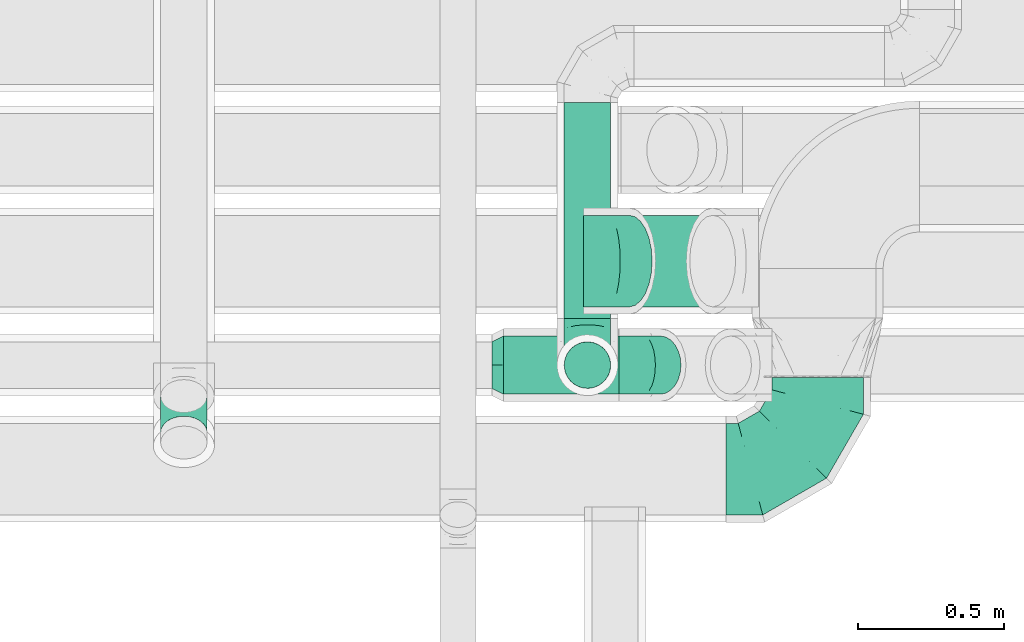
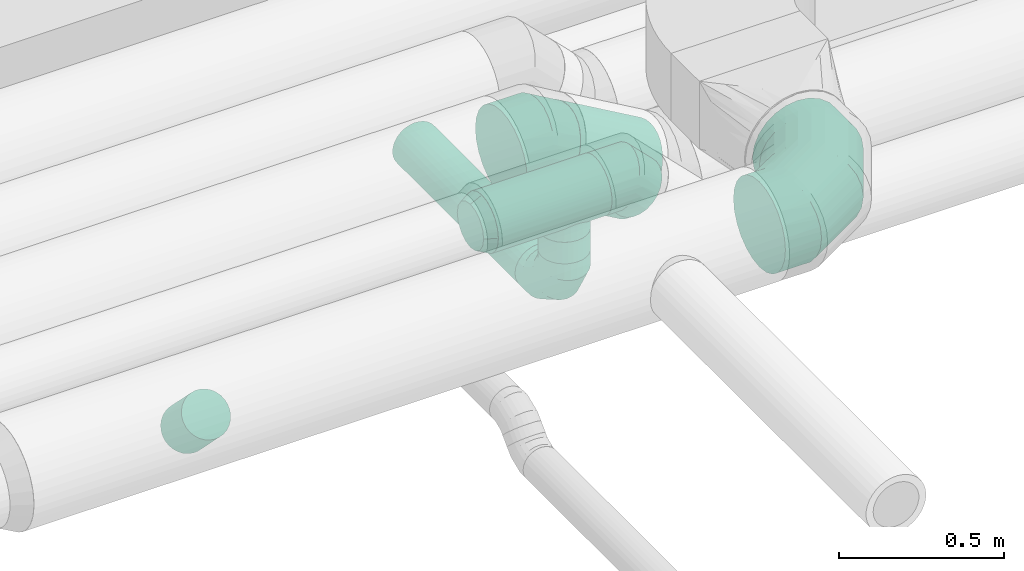
# One storey, part 57 of 92: 6 flow fittings, 5 flow segments.
"""IFC2X3 building model written with IfcOpenShell, lengths in millimetres."""

from ifc_helpers import new_model, entity, si_unit, converted_unit, derived_unit, direction, frame, origin, origin_2d_with_axis, place, context, subcontext, project, spatial, circle, extrude, faceted_brep, source, transform, mapped, material, type_object, type_shapes, element, save


model = new_model("IFC2X3")

# Units and contexts
model_context = context("Model", 3, precision=0.01, world=origin(), true_north=direction((6.12303176911189e-17, 1.0)))
body_context = subcontext(model_context, "Body", "Model", "MODEL_VIEW")
ifc_project = project(units=[si_unit("LENGTHUNIT", "METRE", prefix="MILLI"), si_unit("AREAUNIT", "SQUARE_METRE"), si_unit("VOLUMEUNIT", "CUBIC_METRE"), converted_unit("PLANEANGLEUNIT", "DEGREE", entity("IfcRatioMeasure", 0.0174532925199433), si_unit("PLANEANGLEUNIT", "RADIAN"), dimensions=[0, 0, 0, 0, 0, 0, 0]), si_unit("MASSUNIT", "GRAM", prefix="KILO"), derived_unit("MASSDENSITYUNIT", [(si_unit("MASSUNIT", "GRAM", prefix="KILO"), 1), (si_unit("LENGTHUNIT", "METRE"), -3)]), derived_unit("MOMENTOFINERTIAUNIT", [(si_unit("LENGTHUNIT", "METRE"), 4)]), si_unit("TIMEUNIT", "SECOND"), si_unit("FREQUENCYUNIT", "HERTZ"), si_unit("THERMODYNAMICTEMPERATUREUNIT", "DEGREE_CELSIUS"), derived_unit("THERMALTRANSMITTANCEUNIT", [(si_unit("MASSUNIT", "GRAM", prefix="KILO"), 1), (si_unit("THERMODYNAMICTEMPERATUREUNIT", "KELVIN"), -1), (si_unit("TIMEUNIT", "SECOND"), -3)]), derived_unit("VOLUMETRICFLOWRATEUNIT", [(si_unit("LENGTHUNIT", "METRE"), 3), (si_unit("TIMEUNIT", "SECOND"), -1)]), derived_unit("MASSFLOWRATEUNIT", [(si_unit("MASSUNIT", "GRAM", prefix="KILO"), 1), (si_unit("TIMEUNIT", "SECOND"), -1)]), derived_unit("ROTATIONALFREQUENCYUNIT", [(si_unit("TIMEUNIT", "SECOND"), -1)]), si_unit("ELECTRICCURRENTUNIT", "AMPERE"), si_unit("ELECTRICVOLTAGEUNIT", "VOLT"), si_unit("POWERUNIT", "WATT"), si_unit("FORCEUNIT", "NEWTON", prefix="KILO"), si_unit("ILLUMINANCEUNIT", "LUX"), si_unit("LUMINOUSFLUXUNIT", "LUMEN"), si_unit("LUMINOUSINTENSITYUNIT", "CANDELA"), derived_unit("USERDEFINED", [(si_unit("MASSUNIT", "GRAM", prefix="KILO"), -1), (si_unit("LENGTHUNIT", "METRE"), -2), (si_unit("TIMEUNIT", "SECOND"), 3), (si_unit("LUMINOUSFLUXUNIT", "LUMEN"), 1)]), derived_unit("LINEARVELOCITYUNIT", [(si_unit("LENGTHUNIT", "METRE"), 1), (si_unit("TIMEUNIT", "SECOND"), -1)]), si_unit("PRESSUREUNIT", "PASCAL"), derived_unit("USERDEFINED", [(si_unit("LENGTHUNIT", "METRE"), -2), (si_unit("MASSUNIT", "GRAM", prefix="KILO"), 1), (si_unit("TIMEUNIT", "SECOND"), -2)]), derived_unit("LINEARFORCEUNIT", [(si_unit("MASSUNIT", "GRAM", prefix="KILO"), 1), (si_unit("LENGTHUNIT", "METRE"), 1), (si_unit("TIMEUNIT", "SECOND"), -2), (si_unit("LENGTHUNIT", "METRE"), -1)]), derived_unit("PLANARFORCEUNIT", [(si_unit("MASSUNIT", "GRAM", prefix="KILO"), 1), (si_unit("LENGTHUNIT", "METRE"), 1), (si_unit("TIMEUNIT", "SECOND"), -2), (si_unit("LENGTHUNIT", "METRE"), -2)])], contexts=[model_context])

# Site, building, storey
site_placement = place(None, origin())
site = spatial("IfcSite", under=ifc_project, at=site_placement, CompositionType="ELEMENT")
building_placement = place(site_placement, origin())
building = spatial("IfcBuilding", under=site, at=building_placement, CompositionType="ELEMENT")
storey_placement = place(building_placement, frame((0.0, 0.0, 4200.0)))
storey = spatial("IfcBuildingStorey", under=building, at=storey_placement, CompositionType="ELEMENT", Elevation=4200.0)

# Flow segments
duct_segment_type = type_object("IfcDuctSegmentType", PredefinedType="NOTDEFINED")
flow_segment_1_placement = place(storey_placement, frame((46141.01, 14497.9, 3257.89)))
element("IfcFlowSegment", 1, at=flow_segment_1_placement, inside=storey, type_object=duct_segment_type, context=body_context, shape_type="SweptSolid", body=[
    extrude(circle(Radius=100.0, at=origin_2d_with_axis()), frame((0.0, 101.6, 101.6), z_axis=(1.0, 0.0, 0.0), x_axis=(0.0, -1.0, 0.0)), (0.0, 0.0, 1.0), 397.396622476624),
])
flow_segment_2_placement = place(storey_placement, frame((46492.42, 14797.9, 2954.21)))
element("IfcFlowSegment", 2, at=flow_segment_2_placement, inside=storey, type_object=duct_segment_type, context=body_context, shape_type="SweptSolid", body=[
    extrude(circle(Radius=157.5, at=origin_2d_with_axis()), frame((80.35, 159.1, 303.59), z_axis=(0.866025245734611, 0.0, -0.500000273750232), x_axis=(0.0, 1.0, 0.0)), (0.0, 0.0, 1.0), 331.191628298072),
])
flow_segment_3_placement = place(storey_placement, frame((46347.59, 14759.5, 2918.4)))
element("IfcFlowSegment", 3, at=flow_segment_3_placement, inside=storey, type_object=duct_segment_type, context=body_context, shape_type="SweptSolid", body=[
    extrude(circle(Radius=80.0, at=origin_2d_with_axis()), frame((81.6, 0.0, 81.6), z_axis=(0.0, 1.0, 0.0), x_axis=(-1.0, 0.0, 0.0)), (0.0, 0.0, 1.0), 742.477932121699),
])
flow_segment_4_placement = place(storey_placement, frame((46347.59, 14517.9, 3160.0)))
element("IfcFlowSegment", 4, at=flow_segment_4_placement, inside=storey, type_object=duct_segment_type, context=body_context, shape_type="SweptSolid", body=[
    extrude(circle(Radius=80.0, at=origin_2d_with_axis()), frame((81.6, 81.6, 0.0)), (0.0, 0.0, 1.0), 79.4806650488163),
])
flow_segment_5_placement = place(storey_placement, frame((44960.71, 14308.7, 2989.3)))
element("IfcFlowSegment", 5, at=flow_segment_5_placement, inside=storey, type_object=duct_segment_type, context=body_context, shape_type="SweptSolid", body=[
    extrude(circle(Radius=80.0, at=origin_2d_with_axis()), frame((81.6, 58.36, 184.74), z_axis=(0.0, 0.704591403991659, -0.709613242140437), x_axis=(-1.0, 0.0, 0.0)), (0.0, 0.0, 1.0), 178.658272451828),
])

# Flow fittings
ifc_material = material()
duct_fitting_type_1 = type_object("IfcDuctFittingType", PredefinedType="NOTDEFINED", material=ifc_material)
shared_shape_1 = source(origin(), body_context, "Body", "Brep", [
    faceted_brep([(-160.0, 0.0, -80.0), (-160.0, -20.71, -77.27), (-160.0, -40.0, -69.28), (-160.0, -56.57, -56.57), (-160.0, -69.28, -40.0), (-160.0, -77.27, -20.71), (-160.0, -80.0, 0.0), (-160.0, -77.27, 20.71), (-160.0, -69.28, 40.0), (-160.0, -56.57, 56.57), (-160.0, -40.0, 69.28), (-160.0, -20.71, 77.27), (-160.0, 0.0, 80.0), (-160.0, 20.71, 77.27), (-160.0, 40.0, 69.28), (-160.0, 56.57, 56.57), (-160.0, 69.28, 40.0), (-160.0, 77.27, 20.71), (-160.0, 80.0, 0.0), (-160.0, 77.27, -20.71), (-160.0, 69.28, -40.0), (-160.0, 56.57, -56.57), (-160.0, 40.0, -69.28), (-160.0, 20.71, -77.27), (-122.68, 20.71, 77.27), (-127.85, 40.0, 69.28), (-117.13, 0.0, 80.0), (-132.29, 56.57, 56.57), (-137.83, 77.27, 20.71), (-138.56, 80.0, 0.0), (-135.69, 69.28, 40.0), (-135.69, 69.28, -40.0), (-132.29, 56.57, -56.57), (-137.83, 77.27, -20.71), (-122.68, 20.71, -77.27), (-117.13, 0.0, -80.0), (-127.85, 40.0, -69.28), (-111.58, -20.71, -77.27), (-106.41, -40.0, -69.28), (-101.97, -56.57, -56.57), (-98.56, -69.28, -40.0), (-96.42, -77.27, -20.71), (-95.69, -80.0, 0.0), (-96.42, -77.27, 20.71), (-98.56, -69.28, 40.0), (-101.97, -56.57, 56.57), (-106.41, -40.0, 69.28), (-111.58, -20.71, 77.27), (-58.03, 58.03, 77.27), (-72.15, 72.15, 69.28), (-42.87, 42.87, 80.0), (-84.28, 84.28, 56.57), (-93.59, 93.59, 40.0), (-99.44, 99.44, 20.71), (-101.44, 101.44, 0.0), (-99.44, 99.44, -20.71), (-93.59, 93.59, -40.0), (-84.28, 84.28, -56.57), (-58.03, 58.03, -77.27), (-42.87, 42.87, -80.0), (-72.15, 72.15, -69.28), (-27.71, 27.71, -77.27), (-13.59, 13.59, -69.28), (-1.46, 1.46, -56.57), (7.85, -7.85, -40.0), (13.7, -13.7, -20.71), (15.69, -15.69, 0.0), (13.7, -13.7, 20.71), (7.85, -7.85, 40.0), (-1.46, 1.46, 56.57), (-13.59, 13.59, 69.28), (-27.71, 27.71, 77.27), (-20.71, 122.68, 77.27), (-40.0, 127.85, 69.28), (0.0, 117.13, 80.0), (-56.57, 132.29, 56.57), (-69.28, 135.69, 40.0), (-77.27, 137.83, 20.71), (-80.0, 138.56, 0.0), (-77.27, 137.83, -20.71), (-69.28, 135.69, -40.0), (-56.57, 132.29, -56.57), (-20.71, 122.68, -77.27), (0.0, 117.13, -80.0), (-40.0, 127.85, -69.28), (20.71, 111.58, -77.27), (40.0, 106.41, -69.28), (56.57, 101.97, -56.57), (69.28, 98.56, -40.0), (77.27, 96.42, -20.71), (80.0, 95.69, 0.0), (77.27, 96.42, 20.71), (69.28, 98.56, 40.0), (56.57, 101.97, 56.57), (40.0, 106.41, 69.28), (20.71, 111.58, 77.27), (-20.71, 160.0, -77.27), (-40.0, 160.0, -69.28), (-56.57, 160.0, -56.57), (-69.28, 160.0, -40.0), (-77.27, 160.0, -20.71), (-80.0, 160.0, 0.0), (-77.27, 160.0, 20.71), (-69.28, 160.0, 40.0), (-56.57, 160.0, 56.57), (-40.0, 160.0, 69.28), (-20.71, 160.0, 77.27), (0.0, 160.0, 80.0), (20.71, 160.0, 77.27), (40.0, 160.0, 69.28), (56.57, 160.0, 56.57), (69.28, 160.0, 40.0), (77.27, 160.0, 20.71), (80.0, 160.0, 0.0), (77.27, 160.0, -20.71), (69.28, 160.0, -40.0), (56.57, 160.0, -56.57), (40.0, 160.0, -69.28), (20.71, 160.0, -77.27), (0.0, 160.0, -80.0)], [[[0, 1, 2, 3, 4, 5, 6, 7, 8, 9, 10, 11, 12, 13, 14, 15, 16, 17, 18, 19, 20, 21, 22, 23]], [[24, 25, 14, 13]], [[26, 24, 13, 12]], [[14, 25, 27, 15]], [[28, 29, 18, 17]], [[30, 28, 17, 16]], [[15, 27, 30, 16]], [[20, 31, 32, 21]], [[33, 31, 20, 19]], [[18, 29, 33, 19]], [[34, 35, 0, 23]], [[36, 34, 23, 22]], [[32, 36, 22, 21]], [[1, 0, 35, 37]], [[2, 1, 37, 38]], [[3, 2, 38, 39]], [[5, 4, 40, 41]], [[6, 5, 41, 42]], [[39, 40, 4, 3]], [[6, 42, 43, 7]], [[7, 43, 44, 8]], [[8, 44, 45, 9]], [[9, 45, 46, 10]], [[10, 46, 47, 11]], [[26, 12, 11, 47]], [[48, 49, 25, 24]], [[50, 48, 24, 26]], [[27, 25, 49, 51]], [[52, 53, 28, 30]], [[51, 52, 30, 27]], [[29, 28, 53, 54]], [[55, 56, 31, 33]], [[54, 55, 33, 29]], [[32, 31, 56, 57]], [[58, 59, 35, 34]], [[60, 58, 34, 36]], [[57, 60, 36, 32]], [[37, 35, 59, 61]], [[38, 37, 61, 62]], [[39, 38, 62, 63]], [[41, 40, 64, 65]], [[42, 41, 65, 66]], [[63, 64, 40, 39]], [[43, 42, 66, 67]], [[44, 43, 67, 68]], [[68, 69, 45, 44]], [[46, 45, 69, 70]], [[47, 46, 70, 71]], [[26, 47, 71, 50]], [[72, 73, 49, 48]], [[74, 72, 48, 50]], [[51, 49, 73, 75]], [[76, 77, 53, 52]], [[75, 76, 52, 51]], [[54, 53, 77, 78]], [[79, 80, 56, 55]], [[78, 79, 55, 54]], [[57, 56, 80, 81]], [[82, 83, 59, 58]], [[84, 82, 58, 60]], [[81, 84, 60, 57]], [[61, 59, 83, 85]], [[62, 61, 85, 86]], [[63, 62, 86, 87]], [[65, 64, 88, 89]], [[66, 65, 89, 90]], [[87, 88, 64, 63]], [[67, 66, 90, 91]], [[68, 67, 91, 92]], [[92, 93, 69, 68]], [[70, 69, 93, 94]], [[71, 70, 94, 95]], [[50, 71, 95, 74]], [[96, 97, 98, 99, 100, 101, 102, 103, 104, 105, 106, 107, 108, 109, 110, 111, 112, 113, 114, 115, 116, 117, 118, 119]], [[72, 74, 107, 106]], [[73, 72, 106, 105]], [[75, 73, 105, 104]], [[77, 76, 103, 102]], [[78, 77, 102, 101]], [[75, 104, 103, 76]], [[78, 101, 100, 79]], [[79, 100, 99, 80]], [[80, 99, 98, 81]], [[84, 97, 96, 82]], [[82, 96, 119, 83]], [[84, 81, 98, 97]], [[118, 117, 86, 85]], [[119, 118, 85, 83]], [[116, 87, 86, 117]], [[88, 115, 114, 89]], [[89, 114, 113, 90]], [[115, 88, 87, 116]], [[112, 111, 92, 91]], [[113, 112, 91, 90]], [[111, 110, 93, 92]], [[95, 94, 109, 108]], [[74, 95, 108, 107]], [[110, 109, 94, 93]]]),
])
type_shapes(duct_fitting_type_1, [shared_shape_1])
flow_fitting_1_placement = place(storey_placement, frame((46429.18, 14599.5, 3000.0), z_axis=(-1.0, 0.0, 0.0), x_axis=(0.0, -1.0, 0.0)))
element("IfcFlowFitting", 6, at=flow_fitting_1_placement, inside=storey, type_object=duct_fitting_type_1, material=ifc_material, context=body_context, shape_type="MappedRepresentation", body=[
    mapped(shared_shape_1, transform((0.0, 0.0, 0.0), scale=1.0)),
])
duct_fitting_type_2 = type_object("IfcDuctFittingType", PredefinedType="NOTDEFINED", material=ifc_material)
shared_shape_2 = source(origin(), body_context, "Body", "Brep", [
    faceted_brep([(-82.84, 0.0, -100.0), (-82.84, -25.88, -96.59), (-82.84, -50.0, -86.6), (-82.84, -70.71, -70.71), (-82.84, -86.6, -50.0), (-82.84, -96.59, -25.88), (-82.84, -100.0, 0.0), (-82.84, -96.59, 25.88), (-82.84, -86.6, 50.0), (-82.84, -70.71, 70.71), (-82.84, -50.0, 86.6), (-82.84, -25.88, 96.59), (-82.84, 0.0, 100.0), (-82.84, 25.88, 96.59), (-82.84, 50.0, 86.6), (-82.84, 70.71, 70.71), (-82.84, 86.6, 50.0), (-82.84, 96.59, 25.88), (-82.84, 100.0, 0.0), (-82.84, 96.59, -25.88), (-82.84, 86.6, -50.0), (-82.84, 70.71, -70.71), (-82.84, 50.0, -86.6), (-82.84, 25.88, -96.59), (-10.72, 25.88, 96.59), (-20.71, 50.0, 86.6), (0.0, 0.0, 100.0), (-29.29, 70.71, 70.71), (-35.87, 86.6, 50.0), (-40.01, 96.59, 25.88), (-41.42, 100.0, 0.0), (-40.01, 96.59, -25.88), (-35.87, 86.6, -50.0), (-29.29, 70.71, -70.71), (-10.72, 25.88, -96.59), (0.0, 0.0, -100.0), (-20.71, 50.0, -86.6), (10.72, -25.88, -96.59), (20.71, -50.0, -86.6), (29.29, -70.71, -70.71), (35.87, -86.6, -50.0), (40.01, -96.59, -25.88), (41.42, -100.0, 0.0), (40.01, -96.59, 25.88), (35.87, -86.6, 50.0), (29.29, -70.71, 70.71), (20.71, -50.0, 86.6), (10.72, -25.88, 96.59), (58.58, 58.58, 100.0), (40.28, 76.88, 96.59), (23.22, 93.93, 86.6), (8.58, 108.58, 70.71), (-2.66, 119.82, 50.0), (-9.72, 126.88, 25.88), (-12.13, 129.29, 0.0), (-9.72, 126.88, -25.88), (-2.66, 119.82, -50.0), (8.58, 108.58, -70.71), (23.22, 93.93, -86.6), (40.28, 76.88, -96.59), (58.58, 58.58, -100.0), (76.88, 40.28, -96.59), (93.93, 23.22, -86.6), (108.58, 8.58, -70.71), (119.82, -2.66, -50.0), (126.88, -9.72, -25.88), (129.29, -12.13, 0.0), (126.88, -9.72, 25.88), (119.82, -2.66, 50.0), (108.58, 8.58, 70.71), (93.93, 23.22, 86.6), (76.88, 40.28, 96.59)], [[[0, 1, 2, 3, 4, 5, 6, 7, 8, 9, 10, 11, 12, 13, 14, 15, 16, 17, 18, 19, 20, 21, 22, 23]], [[24, 25, 14, 13]], [[26, 24, 13, 12]], [[14, 25, 27, 15]], [[28, 29, 17, 16]], [[28, 16, 15, 27]], [[30, 18, 17, 29]], [[31, 32, 20, 19]], [[30, 31, 19, 18]], [[32, 33, 21, 20]], [[34, 35, 0, 23]], [[36, 34, 23, 22]], [[33, 36, 22, 21]], [[1, 0, 35, 37]], [[2, 1, 37, 38]], [[38, 39, 3, 2]], [[5, 4, 40, 41]], [[6, 5, 41, 42]], [[39, 40, 4, 3]], [[6, 42, 43, 7]], [[7, 43, 44, 8]], [[8, 44, 45, 9]], [[9, 45, 46, 10]], [[10, 46, 47, 11]], [[26, 12, 11, 47]], [[24, 26, 48, 49]], [[25, 24, 49, 50]], [[27, 25, 50, 51]], [[29, 28, 52, 53]], [[30, 29, 53, 54]], [[51, 52, 28, 27]], [[30, 54, 55, 31]], [[31, 55, 56, 32]], [[57, 33, 32, 56]], [[36, 58, 59, 34]], [[34, 59, 60, 35]], [[58, 36, 33, 57]], [[35, 60, 61, 37]], [[37, 61, 62, 38]], [[63, 39, 38, 62]], [[40, 64, 65, 41]], [[41, 65, 66, 42]], [[64, 40, 39, 63]], [[43, 42, 66, 67]], [[44, 43, 67, 68]], [[68, 69, 45, 44]], [[47, 46, 70, 71]], [[26, 47, 71, 48]], [[69, 70, 46, 45]], [[59, 58, 57, 56, 55, 54, 53, 52, 51, 50, 49, 48, 71, 70, 69, 68, 67, 66, 65, 64, 63, 62, 61, 60]]]),
])
type_shapes(duct_fitting_type_2, [shared_shape_2])
flow_fitting_2_placement = place(storey_placement, frame((46621.25, 14599.5, 3359.48), z_axis=(0.0, 1.0, 0.0), x_axis=(1.0, 0.0, 0.0)))
element("IfcFlowFitting", 7, at=flow_fitting_2_placement, inside=storey, type_object=duct_fitting_type_2, material=ifc_material, context=body_context, shape_type="MappedRepresentation", body=[
    mapped(shared_shape_2, transform((0.0, 0.0, 0.0), scale=1.0)),
])
duct_fitting_type_3 = type_object("IfcDuctFittingType", PredefinedType="NOTDEFINED", material=ifc_material)
shared_shape_3 = source(origin(), body_context, "Body", "Brep", [
    faceted_brep([(20.0, 0.0, -80.0), (20.0, 20.71, -77.27), (20.0, 40.0, -69.28), (20.0, 56.57, -56.57), (20.0, 69.28, -40.0), (20.0, 77.27, -20.71), (20.0, 80.0, 0.0), (20.0, 77.27, 20.71), (20.0, 69.28, 40.0), (20.0, 56.57, 56.57), (20.0, 40.0, 69.28), (20.0, 20.71, 77.27), (20.0, 0.0, 80.0), (20.0, -20.71, 77.27), (20.0, -40.0, 69.28), (20.0, -56.57, 56.57), (20.0, -69.28, 40.0), (20.0, -77.27, 20.71), (20.0, -80.0, 0.0), (20.0, -77.27, -20.71), (20.0, -69.28, -40.0), (20.0, -56.57, -56.57), (20.0, -40.0, -69.28), (20.0, -20.71, -77.27), (0.0, 0.0, 80.0), (-46.1, 0.0, 80.0), (-46.1, -20.71, 77.27), (0.0, -20.71, 77.27), (-46.1, -40.0, 69.28), (0.0, -40.0, 69.28), (0.0, -56.57, 56.57), (-46.1, -56.57, 56.57), (0.0, -69.28, 40.0), (-46.1, -69.28, 40.0), (-46.1, -77.27, 20.71), (0.0, -77.27, 20.71), (-46.1, -80.0, 0.0), (0.0, -80.0, 0.0), (-46.1, -77.27, -20.71), (0.0, -77.27, -20.71), (-46.1, -69.28, -40.0), (0.0, -69.28, -40.0), (0.0, -56.57, -56.57), (-46.1, -56.57, -56.57), (0.0, -40.0, -69.28), (-46.1, -40.0, -69.28), (-46.1, -20.71, -77.27), (0.0, -20.71, -77.27), (-46.1, 0.0, -80.0), (0.0, 0.0, -80.0), (-46.1, 20.71, -77.27), (0.0, 20.71, -77.27), (-46.1, 40.0, -69.28), (0.0, 40.0, -69.28), (0.0, 56.57, -56.57), (-46.1, 56.57, -56.57), (0.0, 69.28, -40.0), (-46.1, 69.28, -40.0), (-46.1, 77.27, -20.71), (0.0, 77.27, -20.71), (-46.1, 80.0, 0.0), (0.0, 80.0, 0.0), (-46.1, 77.27, 20.71), (0.0, 77.27, 20.71), (-46.1, 69.28, 40.0), (0.0, 69.28, 40.0), (0.0, 56.57, 56.57), (-46.1, 56.57, 56.57), (0.0, 40.0, 69.28), (-46.1, 40.0, 69.28), (-46.1, 20.71, 77.27), (0.0, 20.71, 77.27)], [[[0, 1, 2, 3, 4, 5, 6, 7, 8, 9, 10, 11, 12, 13, 14, 15, 16, 17, 18, 19, 20, 21, 22, 23]], [[13, 12, 24, 25, 26, 27]], [[14, 13, 27, 26, 28, 29]], [[30, 15, 14, 29, 28, 31]], [[17, 16, 32, 33, 34, 35]], [[18, 17, 35, 34, 36, 37]], [[32, 16, 15, 30, 31, 33]], [[19, 18, 37, 36, 38, 39]], [[20, 19, 39, 38, 40, 41]], [[42, 21, 20, 41, 40, 43]], [[23, 22, 44, 45, 46, 47]], [[0, 23, 47, 46, 48, 49]], [[44, 22, 21, 42, 43, 45]], [[1, 0, 49, 48, 50, 51]], [[2, 1, 51, 50, 52, 53]], [[54, 3, 2, 53, 52, 55]], [[5, 4, 56, 57, 58, 59]], [[6, 5, 59, 58, 60, 61]], [[56, 4, 3, 54, 55, 57]], [[7, 6, 61, 60, 62, 63]], [[8, 7, 63, 62, 64, 65]], [[66, 9, 8, 65, 64, 67]], [[11, 10, 68, 69, 70, 71]], [[12, 11, 71, 70, 25, 24]], [[68, 10, 9, 66, 67, 69]], [[46, 45, 43, 40, 38, 36, 34, 33, 31, 28, 26, 25, 70, 69, 67, 64, 62, 60, 58, 57, 55, 52, 50, 48]]]),
])
type_shapes(duct_fitting_type_3, [shared_shape_3])
flow_fitting_3_placement = place(storey_placement, frame((46429.18, 14599.5, 3259.48), z_axis=(0.0, -1.0, 0.0), x_axis=(0.0, 0.0, -1.0)))
element("IfcFlowFitting", 8, at=flow_fitting_3_placement, inside=storey, type_object=duct_fitting_type_3, material=ifc_material, context=body_context, shape_type="MappedRepresentation", body=[
    mapped(shared_shape_3, transform((0.0, 0.0, 0.0), scale=1.0)),
])
duct_fitting_type_4 = type_object("IfcDuctFittingType", PredefinedType="NOTDEFINED", material=ifc_material)
shared_shape_4 = source(origin(), body_context, "Body", "Brep", [
    faceted_brep([(40.0, -73.91, 30.61), (40.0, -76.96, 15.31), (40.0, -80.0, 0.0), (40.0, -76.96, -15.31), (40.0, -73.91, -30.61), (40.0, -65.24, -43.59), (40.0, -56.57, -56.57), (40.0, -43.59, -65.24), (40.0, -30.61, -73.91), (40.0, -15.31, -76.96), (40.0, 0.0, -80.0), (40.0, 15.31, -76.96), (40.0, 30.61, -73.91), (40.0, 43.59, -65.24), (40.0, 56.57, -56.57), (40.0, 65.24, -43.59), (40.0, 73.91, -30.61), (40.0, 76.96, -15.31), (40.0, 80.0, 0.0), (40.0, 76.96, 15.31), (40.0, 73.91, 30.61), (40.0, 65.24, 43.59), (40.0, 56.57, 56.57), (40.0, 43.59, 65.24), (40.0, 30.61, 73.91), (40.0, 15.31, 76.96), (40.0, 0.0, 80.0), (40.0, -15.31, 76.96), (40.0, -30.61, 73.91), (40.0, -43.59, 65.24), (40.0, -56.57, 56.57), (40.0, -65.24, 43.59), (0.0, -100.0, 0.0), (0.0, -95.11, 30.9), (0.0, -80.9, 58.78), (0.0, -58.78, 80.9), (0.0, -30.9, 95.11), (0.0, 0.0, 100.0), (0.0, 30.9, 95.11), (0.0, 58.78, 80.9), (0.0, 80.9, 58.78), (0.0, 95.11, 30.9), (0.0, 100.0, 0.0), (0.0, 95.11, -30.9), (0.0, 80.9, -58.78), (0.0, 58.78, -80.9), (0.0, 30.9, -95.11), (0.0, 0.0, -100.0), (0.0, -30.9, -95.11), (0.0, -58.78, -80.9), (0.0, -80.9, -58.78), (0.0, -95.11, -30.9)], [[[0, 1, 2, 3, 4, 5, 6, 7, 8, 9, 10, 11, 12, 13, 14, 15, 16, 17, 18, 19, 20, 21, 22, 23, 24, 25, 26, 27, 28, 29, 30, 31]], [[32, 33, 34, 35, 36, 37, 38, 39, 40, 41, 42, 43, 44, 45, 46, 47, 48, 49, 50, 51]], [[37, 25, 38]], [[25, 24, 38]], [[24, 39, 38]], [[41, 20, 19]], [[25, 37, 26]], [[39, 24, 23, 22]], [[42, 19, 18]], [[20, 40, 22, 21]], [[41, 40, 20]], [[42, 41, 19]], [[22, 40, 39]], [[32, 1, 33]], [[1, 0, 33]], [[0, 34, 33]], [[36, 28, 27]], [[1, 32, 2]], [[34, 0, 31, 30]], [[37, 27, 26]], [[28, 35, 30, 29]], [[36, 35, 28]], [[37, 36, 27]], [[30, 35, 34]], [[47, 9, 48]], [[9, 8, 48]], [[8, 49, 48]], [[51, 4, 3]], [[9, 47, 10]], [[49, 8, 7, 6]], [[32, 3, 2]], [[4, 50, 6, 5]], [[51, 50, 4]], [[32, 51, 3]], [[6, 50, 49]], [[42, 17, 43]], [[17, 16, 43]], [[16, 44, 43]], [[46, 12, 11]], [[17, 42, 18]], [[44, 16, 15, 14]], [[47, 11, 10]], [[12, 45, 14, 13]], [[46, 45, 12]], [[47, 46, 11]], [[14, 45, 44]]]),
])
type_shapes(duct_fitting_type_4, [shared_shape_4])
flow_fitting_4_placement = place(storey_placement, frame((46141.01, 14599.5, 3359.48), z_axis=(0.0, 0.0, 1.0), x_axis=(-1.0, 0.0, 0.0)))
element("IfcFlowFitting", 9, at=flow_fitting_4_placement, inside=storey, type_object=duct_fitting_type_4, material=ifc_material, context=body_context, shape_type="MappedRepresentation", body=[
    mapped(shared_shape_4, transform((0.0, 0.0, 0.0), scale=1.0)),
])
duct_fitting_type_5 = type_object("IfcDuctFittingType", PredefinedType="NOTDEFINED", material=ifc_material)
shared_shape_5 = source(origin(), body_context, "Body", "Brep", [
    faceted_brep([(-315.0, 0.0, -157.5), (-315.0, -40.76, -152.13), (-315.0, -78.75, -136.4), (-315.0, -111.37, -111.37), (-315.0, -136.4, -78.75), (-315.0, -152.13, -40.76), (-315.0, -157.5, 0.0), (-315.0, -152.13, 40.76), (-315.0, -136.4, 78.75), (-315.0, -111.37, 111.37), (-315.0, -78.75, 136.4), (-315.0, -40.76, 152.13), (-315.0, 0.0, 157.5), (-315.0, 40.76, 152.13), (-315.0, 78.75, 136.4), (-315.0, 111.37, 111.37), (-315.0, 136.4, 78.75), (-315.0, 152.13, 40.76), (-315.0, 157.5, 0.0), (-315.0, 152.13, -40.76), (-315.0, 136.4, -78.75), (-315.0, 111.37, -111.37), (-315.0, 78.75, -136.4), (-315.0, 40.76, -152.13), (-241.52, 40.76, 152.13), (-251.7, 78.75, 136.4), (-230.6, 0.0, 157.5), (-260.44, 111.37, 111.37), (-271.36, 152.13, 40.76), (-272.8, 157.5, 0.0), (-267.14, 136.4, 78.75), (-267.14, 136.4, -78.75), (-260.44, 111.37, -111.37), (-271.36, 152.13, -40.76), (-241.52, 40.76, -152.13), (-230.6, 0.0, -157.5), (-251.7, 78.75, -136.4), (-219.67, -40.76, -152.13), (-209.5, -78.75, -136.4), (-200.75, -111.37, -111.37), (-194.05, -136.4, -78.75), (-189.83, -152.13, -40.76), (-188.39, -157.5, 0.0), (-189.83, -152.13, 40.76), (-194.05, -136.4, 78.75), (-200.75, -111.37, 111.37), (-209.5, -78.75, 136.4), (-219.67, -40.76, 152.13), (-114.25, 114.25, 152.13), (-142.05, 142.05, 136.4), (-84.4, 84.4, 157.5), (-165.93, 165.93, 111.37), (-184.25, 184.25, 78.75), (-195.77, 195.77, 40.76), (-199.7, 199.7, 0.0), (-195.77, 195.77, -40.76), (-184.25, 184.25, -78.75), (-165.93, 165.93, -111.37), (-114.25, 114.25, -152.13), (-84.4, 84.4, -157.5), (-142.05, 142.05, -136.4), (-54.56, 54.56, -152.13), (-26.75, 26.75, -136.4), (-2.88, 2.88, -111.37), (15.45, -15.45, -78.75), (26.97, -26.97, -40.76), (30.89, -30.89, 0.0), (26.97, -26.97, 40.76), (15.45, -15.45, 78.75), (-2.88, 2.88, 111.37), (-26.75, 26.75, 136.4), (-54.56, 54.56, 152.13), (-40.76, 241.52, 152.13), (-78.75, 251.7, 136.4), (0.0, 230.6, 157.5), (-111.37, 260.44, 111.37), (-136.4, 267.14, 78.75), (-152.13, 271.36, 40.76), (-157.5, 272.8, 0.0), (-152.13, 271.36, -40.76), (-136.4, 267.14, -78.75), (-111.37, 260.44, -111.37), (-40.76, 241.52, -152.13), (0.0, 230.6, -157.5), (-78.75, 251.7, -136.4), (40.76, 219.67, -152.13), (78.75, 209.5, -136.4), (111.37, 200.75, -111.37), (136.4, 194.05, -78.75), (152.13, 189.83, -40.76), (157.5, 188.39, 0.0), (152.13, 189.83, 40.76), (136.4, 194.05, 78.75), (111.37, 200.75, 111.37), (78.75, 209.5, 136.4), (40.76, 219.67, 152.13), (-40.76, 315.0, -152.13), (-78.75, 315.0, -136.4), (-111.37, 315.0, -111.37), (-136.4, 315.0, -78.75), (-152.13, 315.0, -40.76), (-157.5, 315.0, 0.0), (-152.13, 315.0, 40.76), (-136.4, 315.0, 78.75), (-111.37, 315.0, 111.37), (-78.75, 315.0, 136.4), (-40.76, 315.0, 152.13), (0.0, 315.0, 157.5), (40.76, 315.0, 152.13), (78.75, 315.0, 136.4), (111.37, 315.0, 111.37), (136.4, 315.0, 78.75), (152.13, 315.0, 40.76), (157.5, 315.0, 0.0), (152.13, 315.0, -40.76), (136.4, 315.0, -78.75), (111.37, 315.0, -111.37), (78.75, 315.0, -136.4), (40.76, 315.0, -152.13), (0.0, 315.0, -157.5)], [[[0, 1, 2, 3, 4, 5, 6, 7, 8, 9, 10, 11, 12, 13, 14, 15, 16, 17, 18, 19, 20, 21, 22, 23]], [[24, 25, 14, 13]], [[26, 24, 13, 12]], [[14, 25, 27, 15]], [[28, 29, 18, 17]], [[30, 28, 17, 16]], [[15, 27, 30, 16]], [[20, 31, 32, 21]], [[33, 31, 20, 19]], [[18, 29, 33, 19]], [[34, 35, 0, 23]], [[36, 34, 23, 22]], [[32, 36, 22, 21]], [[1, 0, 35, 37]], [[2, 1, 37, 38]], [[38, 39, 3, 2]], [[5, 4, 40, 41]], [[6, 5, 41, 42]], [[39, 40, 4, 3]], [[6, 42, 43, 7]], [[7, 43, 44, 8]], [[8, 44, 45, 9]], [[9, 45, 46, 10]], [[10, 46, 47, 11]], [[26, 12, 11, 47]], [[48, 49, 25, 24]], [[50, 48, 24, 26]], [[27, 25, 49, 51]], [[52, 53, 28, 30]], [[51, 52, 30, 27]], [[29, 28, 53, 54]], [[55, 56, 31, 33]], [[54, 55, 33, 29]], [[32, 31, 56, 57]], [[58, 59, 35, 34]], [[60, 58, 34, 36]], [[57, 60, 36, 32]], [[37, 35, 59, 61]], [[38, 37, 61, 62]], [[39, 38, 62, 63]], [[41, 40, 64, 65]], [[42, 41, 65, 66]], [[63, 64, 40, 39]], [[43, 42, 66, 67]], [[44, 43, 67, 68]], [[68, 69, 45, 44]], [[46, 45, 69, 70]], [[47, 46, 70, 71]], [[26, 47, 71, 50]], [[72, 73, 49, 48]], [[74, 72, 48, 50]], [[51, 49, 73, 75]], [[76, 77, 53, 52]], [[75, 76, 52, 51]], [[54, 53, 77, 78]], [[79, 80, 56, 55]], [[78, 79, 55, 54]], [[57, 56, 80, 81]], [[82, 83, 59, 58]], [[84, 82, 58, 60]], [[81, 84, 60, 57]], [[61, 59, 83, 85]], [[62, 61, 85, 86]], [[63, 62, 86, 87]], [[65, 64, 88, 89]], [[66, 65, 89, 90]], [[87, 88, 64, 63]], [[67, 66, 90, 91]], [[68, 67, 91, 92]], [[92, 93, 69, 68]], [[70, 69, 93, 94]], [[71, 70, 94, 95]], [[50, 71, 95, 74]], [[96, 97, 98, 99, 100, 101, 102, 103, 104, 105, 106, 107, 108, 109, 110, 111, 112, 113, 114, 115, 116, 117, 118, 119]], [[106, 105, 73, 72]], [[107, 106, 72, 74]], [[75, 73, 105, 104]], [[77, 76, 103, 102]], [[78, 77, 102, 101]], [[104, 103, 76, 75]], [[78, 101, 100, 79]], [[79, 100, 99, 80]], [[98, 81, 80, 99]], [[84, 97, 96, 82]], [[82, 96, 119, 83]], [[97, 84, 81, 98]], [[83, 119, 118, 85]], [[85, 118, 117, 86]], [[116, 87, 86, 117]], [[88, 115, 114, 89]], [[89, 114, 113, 90]], [[115, 88, 87, 116]], [[91, 90, 113, 112]], [[92, 91, 112, 111]], [[111, 110, 93, 92]], [[95, 94, 109, 108]], [[74, 95, 108, 107]], [[110, 109, 94, 93]]]),
])
type_shapes(duct_fitting_type_5, [shared_shape_5])
flow_fitting_5_placement = place(storey_placement, frame((47220.11, 14242.0, 3300.0)))
element("IfcFlowFitting", 10, at=flow_fitting_5_placement, inside=storey, type_object=duct_fitting_type_5, material=ifc_material, context=body_context, shape_type="MappedRepresentation", body=[
    mapped(shared_shape_5, transform((0.0, 0.0, 0.0), scale=1.0)),
])
duct_fitting_type_6 = type_object("IfcDuctFittingType", PredefinedType="NOTDEFINED", material=ifc_material)
shared_shape_6 = source(origin(), body_context, "Body", "Brep", [
    faceted_brep([(-84.4, 0.0, -157.5), (-84.4, -40.76, -152.13), (-84.4, -78.75, -136.4), (-84.4, -111.37, -111.37), (-84.4, -136.4, -78.75), (-84.4, -152.13, -40.76), (-84.4, -157.5, 0.0), (-84.4, -152.13, 40.76), (-84.4, -136.4, 78.75), (-84.4, -111.37, 111.37), (-84.4, -78.75, 136.4), (-84.4, -40.76, 152.13), (-84.4, 0.0, 157.5), (-84.4, 40.76, 152.13), (-84.4, 78.75, 136.4), (-84.4, 111.37, 111.37), (-84.4, 136.4, 78.75), (-84.4, 152.13, 40.76), (-84.4, 157.5, 0.0), (-84.4, 152.13, -40.76), (-84.4, 136.4, -78.75), (-84.4, 111.37, -111.37), (-84.4, 78.75, -136.4), (-84.4, 40.76, -152.13), (-10.92, 40.76, 152.13), (-21.1, 78.75, 136.4), (0.0, 0.0, 157.5), (-29.84, 111.37, 111.37), (-40.76, 152.13, 40.76), (-42.2, 157.5, 0.0), (-36.55, 136.4, 78.75), (-36.55, 136.4, -78.75), (-29.84, 111.37, -111.37), (-40.76, 152.13, -40.76), (-10.92, 40.76, -152.13), (0.0, 0.0, -157.5), (-21.1, 78.75, -136.4), (10.92, -40.76, -152.13), (21.1, -78.75, -136.4), (29.84, -111.37, -111.37), (36.55, -136.4, -78.75), (40.76, -152.13, -40.76), (42.2, -157.5, 0.0), (40.76, -152.13, 40.76), (36.55, -136.4, 78.75), (29.84, -111.37, 111.37), (21.1, -78.75, 136.4), (10.92, -40.76, 152.13), (52.71, 77.5, 152.13), (33.72, 110.4, 136.4), (73.1, 42.2, 157.5), (17.41, 138.65, 111.37), (4.9, 160.33, 78.75), (-2.97, 173.95, 40.76), (-5.65, 178.6, 0.0), (-2.97, 173.95, -40.76), (4.9, 160.33, -78.75), (17.41, 138.65, -111.37), (33.72, 110.4, -136.4), (52.71, 77.5, -152.13), (73.1, 42.2, -157.5), (93.48, 6.9, -152.13), (112.47, -26.0, -136.4), (128.78, -54.25, -111.37), (141.3, -75.92, -78.75), (149.16, -89.55, -40.76), (151.85, -94.2, 0.0), (149.16, -89.55, 40.76), (141.3, -75.92, 78.75), (128.78, -54.25, 111.37), (112.47, -26.0, 136.4), (93.48, 6.9, 152.13)], [[[0, 1, 2, 3, 4, 5, 6, 7, 8, 9, 10, 11, 12, 13, 14, 15, 16, 17, 18, 19, 20, 21, 22, 23]], [[24, 25, 14, 13]], [[26, 24, 13, 12]], [[14, 25, 27, 15]], [[28, 29, 18, 17]], [[30, 28, 17, 16]], [[15, 27, 30, 16]], [[20, 31, 32, 21]], [[33, 31, 20, 19]], [[18, 29, 33, 19]], [[34, 35, 0, 23]], [[36, 34, 23, 22]], [[32, 36, 22, 21]], [[1, 0, 35, 37]], [[2, 1, 37, 38]], [[38, 39, 3, 2]], [[5, 4, 40, 41]], [[6, 5, 41, 42]], [[39, 40, 4, 3]], [[6, 42, 43, 7]], [[7, 43, 44, 8]], [[8, 44, 45, 9]], [[9, 45, 46, 10]], [[10, 46, 47, 11]], [[26, 12, 11, 47]], [[48, 49, 25, 24]], [[50, 48, 24, 26]], [[27, 25, 49, 51]], [[28, 30, 52, 53]], [[29, 28, 53, 54]], [[51, 52, 30, 27]], [[29, 54, 55, 33]], [[33, 55, 56, 31]], [[57, 32, 31, 56]], [[36, 58, 59, 34]], [[34, 59, 60, 35]], [[58, 36, 32, 57]], [[35, 60, 61, 37]], [[37, 61, 62, 38]], [[63, 39, 38, 62]], [[40, 64, 65, 41]], [[41, 65, 66, 42]], [[64, 40, 39, 63]], [[43, 42, 66, 67]], [[44, 43, 67, 68]], [[68, 69, 45, 44]], [[47, 46, 70, 71]], [[26, 47, 71, 50]], [[69, 70, 46, 45]], [[59, 58, 57, 56, 55, 54, 53, 52, 51, 49, 48, 50, 71, 70, 69, 68, 67, 66, 65, 64, 63, 62, 61, 60]]]),
])
type_shapes(duct_fitting_type_6, [shared_shape_6])
flow_fitting_6_placement = place(storey_placement, frame((46499.67, 14957.0, 3300.0), z_axis=(0.0, -1.0, 0.0), x_axis=(-0.866025245734603, 0.0, 0.500000273750245)))
element("IfcFlowFitting", 11, at=flow_fitting_6_placement, inside=storey, type_object=duct_fitting_type_6, material=ifc_material, context=body_context, shape_type="MappedRepresentation", body=[
    mapped(shared_shape_6, transform((0.0, 0.0, 0.0), scale=1.0)),
])

save(model, "model.ifc")
